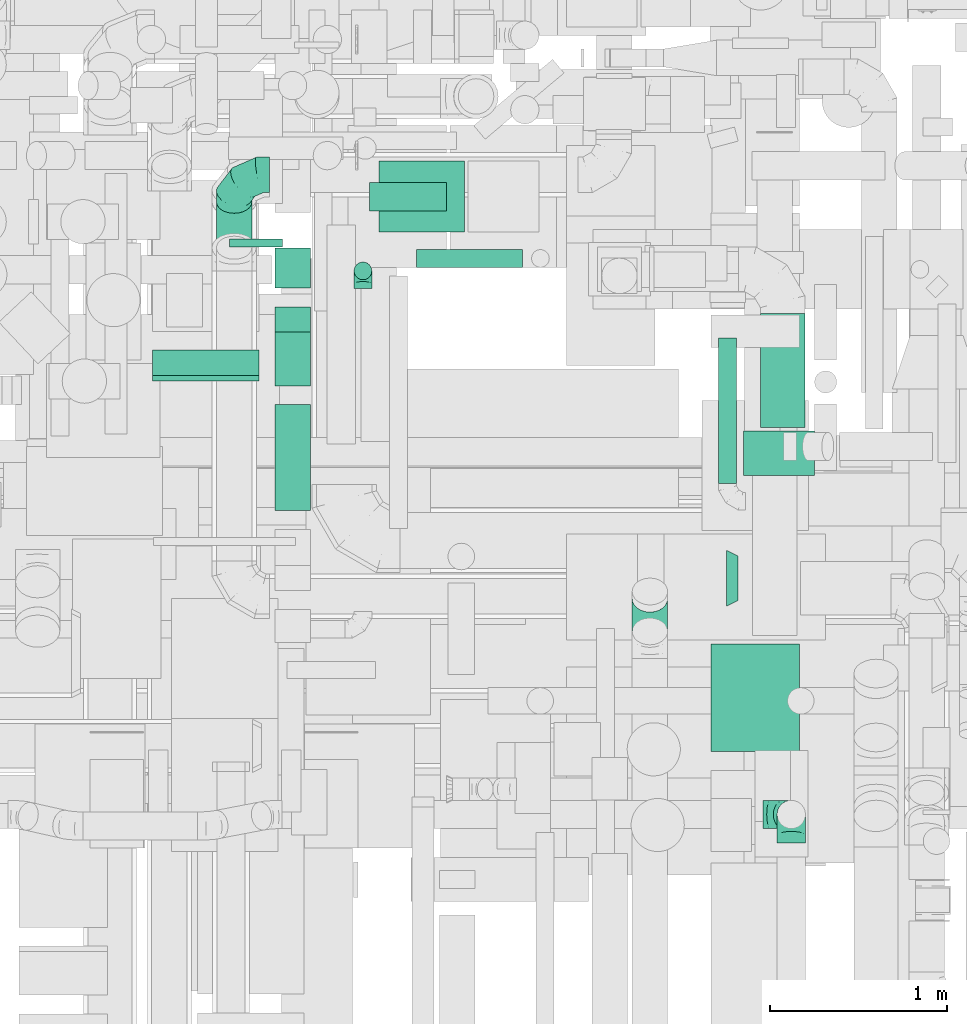
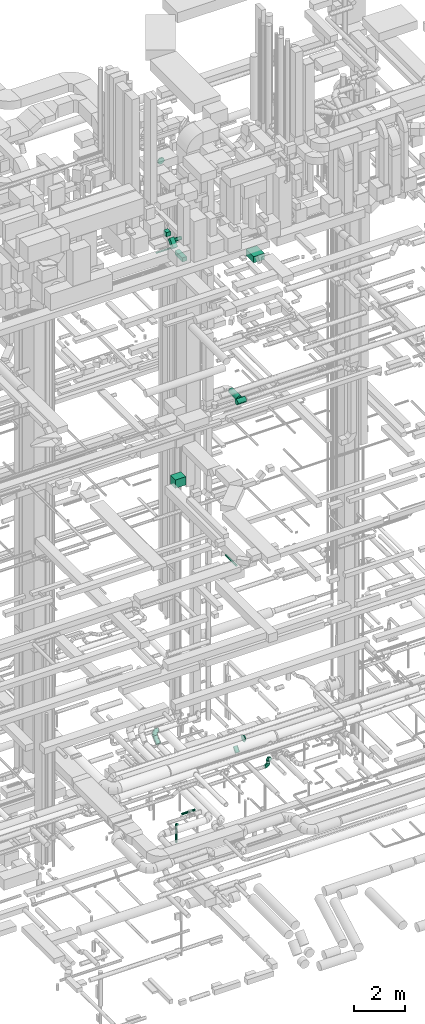
# One storey, part 186 of 337: 15 flow segments, 5 flow fittings.
"""IFC2X3 building model written with IfcOpenShell, lengths in millimetres."""

import ifcopenshell
import ifcopenshell.guid

model = None  # the IFC model being written
_history = None  # IfcOwnerHistory: only IFC2X3 demands one
_inside = {}  # id of a spatial element -> (the spatial element, [elements in it])
_under = {}  # id of a project, library or spatial element -> (it, [spatial elements below it])
_declared = {}  # id of a project -> (the project, [libraries it declares])
_typed = {}  # id of a type object -> (the type object, [elements of that type])
_made_of = {}  # id of a material, layer set ... -> (it, [elements and type objects made of it])


def new_model(schema):
    """Start an empty IFC model of exactly this schema.

    Asked for "IFC4X3", IfcOpenShell would pick the latest addendum, in which some entities
    have other attributes; the version numbers below select the first issue.
    IFC2X3 requires an IfcOwnerHistory on every rooted entity: one is made here for all.
    """
    global model, _history
    if schema == "IFC4X3":
        model = ifcopenshell.file(schema_version=(4, 3, 0, 0))
    else:
        model = ifcopenshell.file(schema=schema)
    _inside.clear()
    _under.clear()
    _declared.clear()
    _typed.clear()
    _made_of.clear()
    _history = None
    if model.schema == "IFC2X3":
        org = make("IfcOrganization", Name="unknown")
        user = make(
            "IfcPersonAndOrganization",
            ThePerson=make("IfcPerson", FamilyName="unknown"),
            TheOrganization=org,
        )
        app = make(
            "IfcApplication",
            ApplicationDeveloper=org,
            Version="unknown",
            ApplicationFullName="unknown",
            ApplicationIdentifier="unknown",
        )
        _history = make(
            "IfcOwnerHistory",
            OwningUser=user,
            OwningApplication=app,
            ChangeAction="ADDED",
            CreationDate=0,
        )
    return model


def make(cls, **values):
    """One entity of the class cls with the attributes given. An attribute that is None is left unset."""
    return model.create_entity(
        cls, **{name: value for name, value in values.items() if value is not None}
    )


def entity(cls, *values):
    """Any entity or typed value of the class cls, its attributes in the order of the schema. None: left unset."""
    e = model.create_entity(cls)
    for i, value in enumerate(values):
        if value is not None:
            e[i] = value
    return e


def rooted(cls, **values):
    """An entity with a GlobalId (a new one), such as an element, a storey or a relation."""
    return make(cls, GlobalId=ifcopenshell.guid.new(), OwnerHistory=_history, **values)


def si_unit(unit_type, name, prefix=None):
    """IfcSIUnit, for example si_unit("LENGTHUNIT", "METRE", prefix="MILLI")."""
    return make("IfcSIUnit", UnitType=unit_type, Prefix=prefix, Name=name)


def converted_unit(unit_type, name, factor, base, dimensions=None, offset=None):
    """IfcConversionBasedUnit, such as the inch: factor (a typed value) times the base unit."""
    return make(
        "IfcConversionBasedUnit"
        if offset is None
        else "IfcConversionBasedUnitWithOffset",
        ConversionOffset=offset,
        Dimensions=None
        if dimensions is None
        else entity("IfcDimensionalExponents", *dimensions),
        UnitType=unit_type,
        Name=name,
        ConversionFactor=make(
            "IfcMeasureWithUnit", ValueComponent=factor, UnitComponent=base
        ),
    )


def derived_unit(unit_type, elements):
    """IfcDerivedUnit: a product of units, each with its exponent."""
    return make(
        "IfcDerivedUnit",
        Elements=[
            make("IfcDerivedUnitElement", Unit=unit, Exponent=power)
            for unit, power in elements
        ],
        UnitType=unit_type,
    )


def assignment(units):
    """IfcUnitAssignment: the units of a project."""
    return None if units is None else make("IfcUnitAssignment", Units=units)


def point(xyz):
    """IfcCartesianPoint."""
    return None if xyz is None else make("IfcCartesianPoint", Coordinates=xyz)


def direction(xyz):
    """IfcDirection."""
    return None if xyz is None else make("IfcDirection", DirectionRatios=xyz)


def frame(location, z_axis=None, x_axis=None):
    """IfcAxis2Placement3D, a coordinate frame: its origin and axes. An axis left out is left unset."""
    return make(
        "IfcAxis2Placement3D",
        Location=point(location),
        Axis=direction(z_axis),
        RefDirection=direction(x_axis),
    )


def frame_2d(location, x_axis=None):
    """IfcAxis2Placement2D, a coordinate frame in the plane: its origin and x axis."""
    return make(
        "IfcAxis2Placement2D", Location=point(location), RefDirection=direction(x_axis)
    )


def origin():
    """The frame at (0, 0, 0) with its axes left unset."""
    return frame((0.0, 0.0, 0.0))


def origin_2d_with_axis():
    """The frame at (0, 0) in the plane with the x axis (1, 0) written out."""
    return frame_2d((0.0, 0.0), x_axis=(1.0, 0.0))


def place(relative_to, where):
    """IfcLocalPlacement: puts the frame where relative to a parent placement (None: the world)."""
    return make(
        "IfcLocalPlacement", PlacementRelTo=relative_to, RelativePlacement=where
    )


def context(
    kind, dimensions, precision=None, world=None, true_north=None, identifier=None
):
    """IfcGeometricRepresentationContext, for example the 3D "Model" context."""
    return make(
        "IfcGeometricRepresentationContext",
        ContextIdentifier=identifier,
        ContextType=kind,
        CoordinateSpaceDimension=dimensions,
        Precision=precision,
        WorldCoordinateSystem=world,
        TrueNorth=true_north,
    )


def subcontext(parent, identifier, kind, view, scale=None):
    """IfcGeometricRepresentationSubContext, for example "Body" below "Model"."""
    return make(
        "IfcGeometricRepresentationSubContext",
        ContextIdentifier=identifier,
        ContextType=kind,
        ParentContext=parent,
        TargetScale=scale,
        TargetView=view,
    )


def project(units=None, contexts=None):
    """IfcProject with its units and contexts."""
    return rooted(
        "IfcProject",
        Name="project",
        RepresentationContexts=contexts,
        UnitsInContext=assignment(units),
    )


def spatial(cls, under=None, at=None, **own):
    """A site, building, storey or space (cls), placed at a placement, below another one or the project."""
    s = rooted(cls, ObjectPlacement=at, **own)
    if under is not None:
        _under.setdefault(under.id(), (under, []))[1].append(s)
    return s


def profile(cls, at=None, kind="AREA", **sizes):
    """A parametric profile (cls). Its sizes go by their IFC names, for example OverallWidth=200.0."""
    return make(cls, ProfileType=kind, Position=at, **sizes)


def rectangle(**sizes):
    """IfcRectangleProfileDef."""
    return profile("IfcRectangleProfileDef", **sizes)


def circle(**sizes):
    """IfcCircleProfileDef."""
    return profile("IfcCircleProfileDef", **sizes)


def extrude(swept, where, along, depth):
    """IfcExtrudedAreaSolid: the profile swept, set in the frame where, extruded along a direction by depth."""
    return make(
        "IfcExtrudedAreaSolid",
        SweptArea=swept,
        Position=where,
        ExtrudedDirection=direction(along),
        Depth=depth,
    )


def faces_of(points, faces, orient=None, outer=None):
    """IfcFace entities. A face is a list of loops; a loop is a list of indices into points, from 0.

    orient and outer hold one flag for each loop. By default every Orientation is true, the
    first loop of a face is its IfcFaceOuterBound and the others are IfcFaceBound.
    """
    made = []
    for i, loops in enumerate(faces):
        bounds = []
        for j, loop in enumerate(loops):
            is_outer = j == 0 if outer is None else outer[i][j]
            bounds.append(
                make(
                    "IfcFaceOuterBound" if is_outer else "IfcFaceBound",
                    Bound=make("IfcPolyLoop", Polygon=[points[k] for k in loop]),
                    Orientation=True if orient is None else orient[i][j],
                )
            )
        made.append(make("IfcFace", Bounds=bounds))
    return made


def faceted_brep(points, faces, orient=None, outer=None, voids=None):
    """IfcFacetedBrep: a solid bounded by flat faces; with voids (closed shells), ...WithVoids."""
    shared = [point(p) for p in points]
    hull = make("IfcClosedShell", CfsFaces=faces_of(shared, faces, orient, outer))
    if voids is None:
        return make("IfcFacetedBrep", Outer=hull)
    return make(
        "IfcFacetedBrepWithVoids",
        Outer=hull,
        Voids=[
            make(cls, CfsFaces=faces_of(shared, fs, o, b)) for cls, fs, o, b in voids
        ],
    )


def shape(context_of_items, identifier, shape_type, items):
    """IfcShapeRepresentation: the items that make up one representation, for example the "Body"."""
    return make(
        "IfcShapeRepresentation",
        ContextOfItems=context_of_items,
        RepresentationIdentifier=identifier,
        RepresentationType=shape_type,
        Items=items,
    )


def source(mapping_origin, context_of_items, identifier, shape_type, items):
    """IfcRepresentationMap: a shape defined once, which mapped items show again and again."""
    return make(
        "IfcRepresentationMap",
        MappingOrigin=mapping_origin,
        MappedRepresentation=shape(context_of_items, identifier, shape_type, items),
    )


def transform(
    local_origin,
    x_axis=None,
    y_axis=None,
    z_axis=None,
    scale=None,
    scale2=None,
    scale3=None,
    uniform=True,
):
    """IfcCartesianTransformationOperator3D, or its non-uniform kind. x_axis, y_axis, z_axis: its Axis1, 2, 3."""
    if uniform:
        return make(
            "IfcCartesianTransformationOperator3D",
            Axis1=direction(x_axis),
            Axis2=direction(y_axis),
            LocalOrigin=point(local_origin),
            Scale=scale,
            Axis3=direction(z_axis),
        )
    return make(
        "IfcCartesianTransformationOperator3DnonUniform",
        Axis1=direction(x_axis),
        Axis2=direction(y_axis),
        LocalOrigin=point(local_origin),
        Scale=scale,
        Axis3=direction(z_axis),
        Scale2=scale2,
        Scale3=scale3,
    )


def mapped(mapping_source, mapping_target):
    """IfcMappedItem: shows the shape of a source again, moved by a transform."""
    return make(
        "IfcMappedItem", MappingSource=mapping_source, MappingTarget=mapping_target
    )


def material(Name=None, Category=None):
    """IfcMaterial."""
    return make("IfcMaterial", Name=Name, Category=Category)


def made_of(thing, what):
    """Note that an element or type object is made of a material, layer set ...; save() writes the relation."""
    if what is not None:
        _made_of.setdefault(what.id(), (what, []))[1].append(thing)
    return thing


def type_object(cls, material=None, **own):
    """A type object (cls), such as IfcWallType, which elements share."""
    return made_of(rooted(cls, **own), material)


def type_shapes(of_type, sources):
    """Give a type object the sources (RepresentationMaps) that its elements show as mapped items."""
    of_type.RepresentationMaps = sources


def element(
    cls,
    number,
    at=None,
    inside=None,
    cuts=None,
    type_object=None,
    material=None,
    context=None,
    identifier="Body",
    shape_type=None,
    held_by="IfcProductDefinitionShape",
    body=None,
    shapes=None,
    **own,
):
    """One element of the class cls, such as IfcWall. Its Tag is "e" and its number.

    at: its placement. inside: the storey or other place that contains it. cuts: it is an
    opening in that element (IfcRelVoidsElement). A single representation is given by context,
    identifier, shape_type and body (its items); several are given by shapes. held_by: the class
    of the entity that holds the representations. save() writes the other relations.
    """
    e = rooted(cls, Tag="e%d" % number, ObjectPlacement=at, **own)
    if body is not None:
        shapes = [shape(context, identifier, shape_type, body)]
    if shapes is not None:
        e.Representation = make(held_by, Representations=shapes)
    if inside is not None:
        _inside.setdefault(inside.id(), (inside, []))[1].append(e)
    if cuts is not None:
        rooted(
            "IfcRelVoidsElement", RelatingBuildingElement=cuts, RelatedOpeningElement=e
        )
    if type_object is not None:
        _typed.setdefault(type_object.id(), (type_object, []))[1].append(e)
    return made_of(e, material)


def aggregate(whole, parts):
    """IfcRelAggregates: a whole, such as a stair, and the parts it consists of."""
    return rooted("IfcRelAggregates", RelatingObject=whole, RelatedObjects=parts)


def save(model, path):
    """Write the relations noted so far, then the file.

    IfcRelAggregates (storeys below a building ...), IfcRelContainedInSpatialStructure (elements
    in a storey), IfcRelDefinesByType, IfcRelAssociatesMaterial and IfcRelDeclares: one each for
    every whole, place, type object, material and project.
    """
    for whole, parts in _under.values():
        aggregate(whole, parts)
    for where, things in _inside.values():
        rooted(
            "IfcRelContainedInSpatialStructure",
            RelatedElements=things,
            RelatingStructure=where,
        )
    for kind, things in _typed.values():
        rooted("IfcRelDefinesByType", RelatedObjects=things, RelatingType=kind)
    for what, things in _made_of.values():
        rooted("IfcRelAssociatesMaterial", RelatedObjects=things, RelatingMaterial=what)
    for by, libraries in _declared.values():
        rooted("IfcRelDeclares", RelatingContext=by, RelatedDefinitions=libraries)
    model.write(path)


model = new_model("IFC2X3")

# Units and contexts
model_context = context("Model", 3, precision=0.01, world=origin(), true_north=direction((6.12303176911189e-17, 1.0)))
body_context = subcontext(model_context, "Body", "Model", "MODEL_VIEW")
ifc_project = project(units=[si_unit("LENGTHUNIT", "METRE", prefix="MILLI"), si_unit("AREAUNIT", "SQUARE_METRE"), si_unit("VOLUMEUNIT", "CUBIC_METRE"), converted_unit("PLANEANGLEUNIT", "DEGREE", entity("IfcRatioMeasure", 0.0174532925199433), si_unit("PLANEANGLEUNIT", "RADIAN"), dimensions=[0, 0, 0, 0, 0, 0, 0]), si_unit("MASSUNIT", "GRAM", prefix="KILO"), derived_unit("MASSDENSITYUNIT", [(si_unit("MASSUNIT", "GRAM", prefix="KILO"), 1), (si_unit("LENGTHUNIT", "METRE"), -3)]), derived_unit("MOMENTOFINERTIAUNIT", [(si_unit("LENGTHUNIT", "METRE"), 4)]), si_unit("TIMEUNIT", "SECOND"), si_unit("FREQUENCYUNIT", "HERTZ"), si_unit("THERMODYNAMICTEMPERATUREUNIT", "DEGREE_CELSIUS"), derived_unit("THERMALTRANSMITTANCEUNIT", [(si_unit("MASSUNIT", "GRAM", prefix="KILO"), 1), (si_unit("THERMODYNAMICTEMPERATUREUNIT", "KELVIN"), -1), (si_unit("TIMEUNIT", "SECOND"), -3)]), derived_unit("VOLUMETRICFLOWRATEUNIT", [(si_unit("LENGTHUNIT", "METRE"), 3), (si_unit("TIMEUNIT", "SECOND"), -1)]), derived_unit("MASSFLOWRATEUNIT", [(si_unit("MASSUNIT", "GRAM", prefix="KILO"), 1), (si_unit("TIMEUNIT", "SECOND"), -1)]), derived_unit("ROTATIONALFREQUENCYUNIT", [(si_unit("TIMEUNIT", "SECOND"), -1)]), si_unit("ELECTRICCURRENTUNIT", "AMPERE"), si_unit("ELECTRICVOLTAGEUNIT", "VOLT"), si_unit("POWERUNIT", "WATT"), si_unit("FORCEUNIT", "NEWTON", prefix="KILO"), si_unit("ILLUMINANCEUNIT", "LUX"), si_unit("LUMINOUSFLUXUNIT", "LUMEN"), si_unit("LUMINOUSINTENSITYUNIT", "CANDELA"), derived_unit("USERDEFINED", [(si_unit("MASSUNIT", "GRAM", prefix="KILO"), -1), (si_unit("LENGTHUNIT", "METRE"), -2), (si_unit("TIMEUNIT", "SECOND"), 3), (si_unit("LUMINOUSFLUXUNIT", "LUMEN"), 1)]), derived_unit("LINEARVELOCITYUNIT", [(si_unit("LENGTHUNIT", "METRE"), 1), (si_unit("TIMEUNIT", "SECOND"), -1)]), si_unit("PRESSUREUNIT", "PASCAL"), derived_unit("USERDEFINED", [(si_unit("LENGTHUNIT", "METRE"), -2), (si_unit("MASSUNIT", "GRAM", prefix="KILO"), 1), (si_unit("TIMEUNIT", "SECOND"), -2)]), derived_unit("LINEARFORCEUNIT", [(si_unit("MASSUNIT", "GRAM", prefix="KILO"), 1), (si_unit("LENGTHUNIT", "METRE"), 1), (si_unit("TIMEUNIT", "SECOND"), -2), (si_unit("LENGTHUNIT", "METRE"), -1)]), derived_unit("PLANARFORCEUNIT", [(si_unit("MASSUNIT", "GRAM", prefix="KILO"), 1), (si_unit("LENGTHUNIT", "METRE"), 1), (si_unit("TIMEUNIT", "SECOND"), -2), (si_unit("LENGTHUNIT", "METRE"), -2)])], contexts=[model_context])

# Site, building, storey
site_placement = place(None, origin())
site = spatial("IfcSite", under=ifc_project, at=site_placement, CompositionType="ELEMENT")
building_placement = place(site_placement, origin())
building = spatial("IfcBuilding", under=site, at=building_placement, CompositionType="ELEMENT")
storey_placement = place(building_placement, origin())
storey = spatial("IfcBuildingStorey", under=building, at=storey_placement, CompositionType="ELEMENT", Elevation=0.0)

# Flow segments
duct_segment_type_1 = type_object("IfcDuctSegmentType", PredefinedType="NOTDEFINED")
flow_segment_1_placement = place(storey_placement, frame((51245.32, 11485.34, 15050.0)))
element("IfcFlowSegment", 1, at=flow_segment_1_placement, inside=storey, type_object=duct_segment_type_1, context=body_context, shape_type="SweptSolid", body=[
    extrude(rectangle(XDim=479.889877624802, YDim=400.0, at=origin_2d_with_axis()), frame((239.94, 200.0, 0.0), z_axis=(0.0, 0.0, 1.0), x_axis=(-1.0, 0.0, 0.0)), (0.0, 0.0, 1.0), 400.0),
])
flow_segment_2_placement = place(storey_placement, frame((49966.44, 10643.16, 27222.51)))
element("IfcFlowSegment", 2, at=flow_segment_2_placement, inside=storey, type_object=duct_segment_type_1, context=body_context, shape_type="SweptSolid", body=[
    extrude(rectangle(XDim=47.451660040764, YDim=199.999999999996, at=origin_2d_with_axis()), frame((0.0, 87.49, 87.49), z_axis=(1.0, 0.0, 0.0), x_axis=(0.0, -0.707106781186502, -0.707106781186593)), (0.0, 0.0, 1.0), 600.000000000002),
])
flow_segment_3_placement = place(storey_placement, frame((50656.62, 9913.65, 27100.0)))
element("IfcFlowSegment", 3, at=flow_segment_3_placement, inside=storey, type_object=duct_segment_type_1, context=body_context, shape_type="SweptSolid", body=[
    extrude(rectangle(XDim=597.695447254163, YDim=199.999999999998, at=origin_2d_with_axis()), frame((100.0, 298.85, 0.0), z_axis=(0.0, 0.0, 1.0), x_axis=(0.0, 1.0, 0.0)), (0.0, 0.0, 1.0), 199.999999999998),
])
flow_segment_4_placement = place(storey_placement, frame((50656.62, 11168.45, 27550.0)))
element("IfcFlowSegment", 4, at=flow_segment_4_placement, inside=storey, type_object=duct_segment_type_1, context=body_context, shape_type="SweptSolid", body=[
    extrude(rectangle(XDim=227.123541719797, YDim=199.999999999998, at=origin_2d_with_axis()), frame((100.0, 113.56, 0.0), z_axis=(0.0, 0.0, 1.0), x_axis=(0.0, -1.0, 0.0)), (0.0, 0.0, 1.0), 199.999999999998),
])
flow_segment_5_placement = place(storey_placement, frame((50656.62, 10617.41, 27202.51)))
element("IfcFlowSegment", 5, at=flow_segment_5_placement, inside=storey, type_object=duct_segment_type_1, context=body_context, shape_type="SweptSolid", body=[
    extrude(rectangle(XDim=200.000000000001, YDim=200.000000000007, at=frame_2d((0.0, 0.0), x_axis=(0.0, 1.0))), frame((100.0, 70.71, 70.71), z_axis=(0.0, 0.707106781186526, 0.707106781186569), x_axis=(-1.0, 0.0, 0.0)), (0.0, 0.0, 1.0), 429.28932188139),
])
flow_segment_6_placement = place(storey_placement, frame((53115.82, 8554.1, 27020.0)))
element("IfcFlowSegment", 6, at=flow_segment_6_placement, inside=storey, type_object=duct_segment_type_1, context=body_context, shape_type="SweptSolid", body=[
    extrude(rectangle(XDim=608.455931288087, YDim=499.999999999999, at=origin_2d_with_axis()), frame((250.0, 304.23, 0.0), z_axis=(0.0, 0.0, 1.0), x_axis=(0.0, -1.0, 0.0)), (0.0, 0.0, 1.0), 300.000000000001),
])
duct_segment_type_2 = type_object("IfcDuctSegmentType", PredefinedType="NOTDEFINED")
flow_segment_7_placement = place(storey_placement, frame((51101.93, 11213.41, -1800.0)))
element("IfcFlowSegment", 7, at=flow_segment_7_placement, inside=storey, type_object=duct_segment_type_2, context=body_context, shape_type="SweptSolid", body=[
    extrude(circle(Radius=50.0, at=origin_2d_with_axis()), frame((51.6, 51.6, 0.0), z_axis=(0.0, 0.0, 1.0), x_axis=(-1.0, 0.0, 0.0)), (0.0, 0.0, 1.0), 799.999999999994),
])
flow_segment_8_placement = place(storey_placement, frame((53158.29, 10066.79, 11468.4)))
element("IfcFlowSegment", 8, at=flow_segment_8_placement, inside=storey, type_object=duct_segment_type_2, context=body_context, shape_type="SweptSolid", body=[
    extrude(circle(Radius=50.0, at=origin_2d_with_axis()), frame((51.6, 0.0, 51.6), z_axis=(0.0, 1.0, 0.0), x_axis=(1.0, 0.0, 0.0)), (0.0, 0.0, 1.0), 820.000000000015),
])
flow_segment_9_placement = place(storey_placement, frame((53393.29, 10382.4, 19123.4)))
element("IfcFlowSegment", 9, at=flow_segment_9_placement, inside=storey, type_object=duct_segment_type_2, context=body_context, shape_type="SweptSolid", body=[
    extrude(circle(Radius=125.0, at=origin_2d_with_axis()), frame((126.6, 0.0, 126.6), z_axis=(0.0, 1.0, 0.0), x_axis=(-1.0, 0.0, 0.0)), (0.0, 0.0, 1.0), 642.208810038309),
])
flow_segment_10_placement = place(storey_placement, frame((53299.89, 10110.8, 19123.4)))
element("IfcFlowSegment", 10, at=flow_segment_10_placement, inside=storey, type_object=duct_segment_type_2, context=body_context, shape_type="SweptSolid", body=[
    extrude(circle(Radius=125.0, at=origin_2d_with_axis()), frame((0.0, 126.6, 126.6), z_axis=(1.0, 0.0, 0.0), x_axis=(0.0, -1.0, 0.0)), (0.0, 0.0, 1.0), 399.999999999996),
])
flow_segment_11_placement = place(storey_placement, frame((51190.74, 11602.23, 26778.4)))
element("IfcFlowSegment", 11, at=flow_segment_11_placement, inside=storey, type_object=duct_segment_type_2, context=body_context, shape_type="SweptSolid", body=[
    extrude(circle(Radius=80.0, at=origin_2d_with_axis()), frame((0.0, 81.6, 81.6), z_axis=(1.0, 0.0, 0.0), x_axis=(0.0, 1.0, 0.0)), (0.0, 0.0, 1.0), 434.464444213462),
])
flow_segment_12_placement = place(storey_placement, frame((50398.26, 11400.25, 30948.4)))
element("IfcFlowSegment", 12, at=flow_segment_12_placement, inside=storey, type_object=duct_segment_type_2, context=body_context, shape_type="SweptSolid", body=[
    extrude(circle(Radius=150.0, at=origin_2d_with_axis()), frame((151.6, 0.0, 151.6), z_axis=(0.0, 1.0, 0.0), x_axis=(1.0, 0.0, 0.0)), (0.0, 0.0, 1.0), 46.000000000009),
])
flow_segment_13_placement = place(storey_placement, frame((51454.28, 11283.75, -651.6)))
element("IfcFlowSegment", 13, at=flow_segment_13_placement, inside=storey, type_object=duct_segment_type_2, context=body_context, shape_type="SweptSolid", body=[
    extrude(circle(Radius=50.0, at=origin_2d_with_axis()), frame((0.0, 51.6, 51.6), z_axis=(1.0, 0.0, 0.0), x_axis=(0.0, 1.0, 0.0)), (0.0, 0.0, 1.0), 600.000000000011),
])
flow_segment_14_placement = place(storey_placement, frame((52670.27, 9154.84, 3103.17)))
element("IfcFlowSegment", 14, at=flow_segment_14_placement, inside=storey, type_object=duct_segment_type_2, context=body_context, shape_type="SweptSolid", body=[
    extrude(circle(Radius=100.0, at=origin_2d_with_axis()), frame((101.6, 77.52, 66.67), z_axis=(0.0, 0.650791373455976, 0.75925660236529), x_axis=(1.0, 0.0, 0.0)), (0.0, 0.0, 1.0), 283.68568294348),
])
flow_segment_15_placement = place(storey_placement, frame((50325.56, 11329.47, 3020.56)))
element("IfcFlowSegment", 15, at=flow_segment_15_placement, inside=storey, type_object=duct_segment_type_2, context=body_context, shape_type="SweptSolid", body=[
    extrude(circle(Radius=100.0, at=origin_2d_with_axis()), frame((101.6, 66.65, 77.54), z_axis=(0.0, 0.759487168515649, 0.650522283138773), x_axis=(-1.0, 0.0, 0.0)), (0.0, 0.0, 1.0), 340.946010343046),
])

# Flow fittings
ifc_material = material()
duct_fitting_type_1 = type_object("IfcDuctFittingType", PredefinedType="NOTDEFINED", material=ifc_material)
shared_shape_1 = source(origin(), body_context, "Body", "Brep", [
    faceted_brep([(-160.0, 0.0, -80.0), (-160.0, -20.71, -77.27), (-160.0, -40.0, -69.28), (-160.0, -56.57, -56.57), (-160.0, -69.28, -40.0), (-160.0, -77.27, -20.71), (-160.0, -80.0, 0.0), (-160.0, -77.27, 20.71), (-160.0, -69.28, 40.0), (-160.0, -56.57, 56.57), (-160.0, -40.0, 69.28), (-160.0, -20.71, 77.27), (-160.0, 0.0, 80.0), (-160.0, 20.71, 77.27), (-160.0, 40.0, 69.28), (-160.0, 56.57, 56.57), (-160.0, 69.28, 40.0), (-160.0, 77.27, 20.71), (-160.0, 80.0, 0.0), (-160.0, 77.27, -20.71), (-160.0, 69.28, -40.0), (-160.0, 56.57, -56.57), (-160.0, 40.0, -69.28), (-160.0, 20.71, -77.27), (-122.68, 20.71, 77.27), (-127.85, 40.0, 69.28), (-117.13, 0.0, 80.0), (-132.29, 56.57, 56.57), (-137.83, 77.27, 20.71), (-138.56, 80.0, 0.0), (-135.69, 69.28, 40.0), (-135.69, 69.28, -40.0), (-132.29, 56.57, -56.57), (-137.83, 77.27, -20.71), (-122.68, 20.71, -77.27), (-117.13, 0.0, -80.0), (-127.85, 40.0, -69.28), (-111.58, -20.71, -77.27), (-106.41, -40.0, -69.28), (-101.97, -56.57, -56.57), (-98.56, -69.28, -40.0), (-96.42, -77.27, -20.71), (-95.69, -80.0, 0.0), (-96.42, -77.27, 20.71), (-98.56, -69.28, 40.0), (-101.97, -56.57, 56.57), (-106.41, -40.0, 69.28), (-111.58, -20.71, 77.27), (-58.03, 58.03, 77.27), (-72.15, 72.15, 69.28), (-42.87, 42.87, 80.0), (-84.28, 84.28, 56.57), (-93.59, 93.59, 40.0), (-99.44, 99.44, 20.71), (-101.44, 101.44, 0.0), (-99.44, 99.44, -20.71), (-93.59, 93.59, -40.0), (-84.28, 84.28, -56.57), (-58.03, 58.03, -77.27), (-42.87, 42.87, -80.0), (-72.15, 72.15, -69.28), (-27.71, 27.71, -77.27), (-13.59, 13.59, -69.28), (-1.46, 1.46, -56.57), (7.85, -7.85, -40.0), (13.7, -13.7, -20.71), (15.69, -15.69, 0.0), (13.7, -13.7, 20.71), (7.85, -7.85, 40.0), (-1.46, 1.46, 56.57), (-13.59, 13.59, 69.28), (-27.71, 27.71, 77.27), (-20.71, 122.68, 77.27), (-40.0, 127.85, 69.28), (0.0, 117.13, 80.0), (-56.57, 132.29, 56.57), (-69.28, 135.69, 40.0), (-77.27, 137.83, 20.71), (-80.0, 138.56, 0.0), (-77.27, 137.83, -20.71), (-69.28, 135.69, -40.0), (-56.57, 132.29, -56.57), (-20.71, 122.68, -77.27), (0.0, 117.13, -80.0), (-40.0, 127.85, -69.28), (20.71, 111.58, -77.27), (40.0, 106.41, -69.28), (56.57, 101.97, -56.57), (69.28, 98.56, -40.0), (77.27, 96.42, -20.71), (80.0, 95.69, 0.0), (77.27, 96.42, 20.71), (69.28, 98.56, 40.0), (56.57, 101.97, 56.57), (40.0, 106.41, 69.28), (20.71, 111.58, 77.27), (-20.71, 160.0, -77.27), (-40.0, 160.0, -69.28), (-56.57, 160.0, -56.57), (-69.28, 160.0, -40.0), (-77.27, 160.0, -20.71), (-80.0, 160.0, 0.0), (-77.27, 160.0, 20.71), (-69.28, 160.0, 40.0), (-56.57, 160.0, 56.57), (-40.0, 160.0, 69.28), (-20.71, 160.0, 77.27), (0.0, 160.0, 80.0), (20.71, 160.0, 77.27), (40.0, 160.0, 69.28), (56.57, 160.0, 56.57), (69.28, 160.0, 40.0), (77.27, 160.0, 20.71), (80.0, 160.0, 0.0), (77.27, 160.0, -20.71), (69.28, 160.0, -40.0), (56.57, 160.0, -56.57), (40.0, 160.0, -69.28), (20.71, 160.0, -77.27), (0.0, 160.0, -80.0)], [[[0, 1, 2, 3, 4, 5, 6, 7, 8, 9, 10, 11, 12, 13, 14, 15, 16, 17, 18, 19, 20, 21, 22, 23]], [[24, 25, 14, 13]], [[26, 24, 13, 12]], [[14, 25, 27, 15]], [[28, 29, 18, 17]], [[30, 28, 17, 16]], [[15, 27, 30, 16]], [[20, 31, 32, 21]], [[33, 31, 20, 19]], [[18, 29, 33, 19]], [[34, 35, 0, 23]], [[36, 34, 23, 22]], [[32, 36, 22, 21]], [[1, 0, 35, 37]], [[2, 1, 37, 38]], [[3, 2, 38, 39]], [[5, 4, 40, 41]], [[6, 5, 41, 42]], [[39, 40, 4, 3]], [[6, 42, 43, 7]], [[7, 43, 44, 8]], [[8, 44, 45, 9]], [[9, 45, 46, 10]], [[10, 46, 47, 11]], [[26, 12, 11, 47]], [[48, 49, 25, 24]], [[50, 48, 24, 26]], [[27, 25, 49, 51]], [[52, 53, 28, 30]], [[51, 52, 30, 27]], [[29, 28, 53, 54]], [[55, 56, 31, 33]], [[54, 55, 33, 29]], [[32, 31, 56, 57]], [[58, 59, 35, 34]], [[60, 58, 34, 36]], [[57, 60, 36, 32]], [[37, 35, 59, 61]], [[38, 37, 61, 62]], [[39, 38, 62, 63]], [[41, 40, 64, 65]], [[42, 41, 65, 66]], [[63, 64, 40, 39]], [[43, 42, 66, 67]], [[44, 43, 67, 68]], [[68, 69, 45, 44]], [[46, 45, 69, 70]], [[47, 46, 70, 71]], [[26, 47, 71, 50]], [[72, 73, 49, 48]], [[74, 72, 48, 50]], [[51, 49, 73, 75]], [[76, 77, 53, 52]], [[75, 76, 52, 51]], [[54, 53, 77, 78]], [[79, 80, 56, 55]], [[78, 79, 55, 54]], [[57, 56, 80, 81]], [[82, 83, 59, 58]], [[84, 82, 58, 60]], [[81, 84, 60, 57]], [[61, 59, 83, 85]], [[62, 61, 85, 86]], [[63, 62, 86, 87]], [[65, 64, 88, 89]], [[66, 65, 89, 90]], [[87, 88, 64, 63]], [[67, 66, 90, 91]], [[68, 67, 91, 92]], [[92, 93, 69, 68]], [[70, 69, 93, 94]], [[71, 70, 94, 95]], [[50, 71, 95, 74]], [[96, 97, 98, 99, 100, 101, 102, 103, 104, 105, 106, 107, 108, 109, 110, 111, 112, 113, 114, 115, 116, 117, 118, 119]], [[72, 74, 107, 106]], [[73, 72, 106, 105]], [[75, 73, 105, 104]], [[77, 76, 103, 102]], [[78, 77, 102, 101]], [[75, 104, 103, 76]], [[78, 101, 100, 79]], [[79, 100, 99, 80]], [[80, 99, 98, 81]], [[84, 97, 96, 82]], [[82, 96, 119, 83]], [[84, 81, 98, 97]], [[118, 117, 86, 85]], [[119, 118, 85, 83]], [[116, 87, 86, 117]], [[88, 115, 114, 89]], [[89, 114, 113, 90]], [[115, 88, 87, 116]], [[112, 111, 92, 91]], [[113, 112, 91, 90]], [[111, 110, 93, 92]], [[95, 94, 109, 108]], [[74, 95, 108, 107]], [[110, 109, 94, 93]]]),
])
type_shapes(duct_fitting_type_1, [shared_shape_1])
for number, where, z_axis, x_axis in (
    (16, (53568.9, 8200.02, 3300.0), (-1.0, 0.0, 0.0), (0.0, 1.0, 0.0)),
    (17, (53568.9, 8200.02, 2900.0), (0.0, 1.0, 0.0), (0.0, 0.0, -1.0)),
):
    element("IfcFlowFitting", number, at=place(storey_placement, frame(where, z_axis=z_axis, x_axis=x_axis)), inside=storey, type_object=duct_fitting_type_1, material=ifc_material, context=body_context, shape_type="MappedRepresentation", body=[
        mapped(shared_shape_1, transform((0.0, 0.0, 0.0), scale=1.0)),
    ])
duct_fitting_type_2 = type_object("IfcDuctFittingType", PredefinedType="NOTDEFINED", material=ifc_material)
shared_shape_2 = source(origin(), body_context, "Body", "Brep", [
    faceted_brep([(-100.0, 0.0, -50.0), (-100.0, -12.94, -48.3), (-100.0, -25.0, -43.3), (-100.0, -35.36, -35.36), (-100.0, -43.3, -25.0), (-100.0, -48.3, -12.94), (-100.0, -50.0, 0.0), (-100.0, -48.3, 12.94), (-100.0, -43.3, 25.0), (-100.0, -35.36, 35.36), (-100.0, -25.0, 43.3), (-100.0, -12.94, 48.3), (-100.0, 0.0, 50.0), (-100.0, 12.94, 48.3), (-100.0, 25.0, 43.3), (-100.0, 35.36, 35.36), (-100.0, 43.3, 25.0), (-100.0, 48.3, 12.94), (-100.0, 50.0, 0.0), (-100.0, 48.3, -12.94), (-100.0, 43.3, -25.0), (-100.0, 35.36, -35.36), (-100.0, 25.0, -43.3), (-100.0, 12.94, -48.3), (-76.67, 12.94, 48.3), (-79.9, 25.0, 43.3), (-73.21, 0.0, 50.0), (-82.68, 35.36, 35.36), (-86.15, 48.3, 12.94), (-86.6, 50.0, 0.0), (-84.81, 43.3, 25.0), (-84.81, 43.3, -25.0), (-82.68, 35.36, -35.36), (-86.15, 48.3, -12.94), (-76.67, 12.94, -48.3), (-73.21, 0.0, -50.0), (-79.9, 25.0, -43.3), (-69.74, -12.94, -48.3), (-66.51, -25.0, -43.3), (-63.73, -35.36, -35.36), (-61.6, -43.3, -25.0), (-60.26, -48.3, -12.94), (-59.81, -50.0, 0.0), (-60.26, -48.3, 12.94), (-61.6, -43.3, 25.0), (-63.73, -35.36, 35.36), (-66.51, -25.0, 43.3), (-69.74, -12.94, 48.3), (-36.27, 36.27, 48.3), (-45.1, 45.1, 43.3), (-26.79, 26.79, 50.0), (-52.68, 52.68, 35.36), (-58.49, 58.49, 25.0), (-62.15, 62.15, 12.94), (-63.4, 63.4, 0.0), (-62.15, 62.15, -12.94), (-58.49, 58.49, -25.0), (-52.68, 52.68, -35.36), (-36.27, 36.27, -48.3), (-26.79, 26.79, -50.0), (-45.1, 45.1, -43.3), (-17.32, 17.32, -48.3), (-8.49, 8.49, -43.3), (-0.91, 0.91, -35.36), (4.9, -4.9, -25.0), (8.56, -8.56, -12.94), (9.81, -9.81, 0.0), (8.56, -8.56, 12.94), (4.9, -4.9, 25.0), (-0.91, 0.91, 35.36), (-8.49, 8.49, 43.3), (-17.32, 17.32, 48.3), (-12.94, 76.67, 48.3), (-25.0, 79.9, 43.3), (0.0, 73.21, 50.0), (-35.36, 82.68, 35.36), (-43.3, 84.81, 25.0), (-48.3, 86.15, 12.94), (-50.0, 86.6, 0.0), (-48.3, 86.15, -12.94), (-43.3, 84.81, -25.0), (-35.36, 82.68, -35.36), (-12.94, 76.67, -48.3), (0.0, 73.21, -50.0), (-25.0, 79.9, -43.3), (12.94, 69.74, -48.3), (25.0, 66.51, -43.3), (35.36, 63.73, -35.36), (43.3, 61.6, -25.0), (48.3, 60.26, -12.94), (50.0, 59.81, 0.0), (48.3, 60.26, 12.94), (43.3, 61.6, 25.0), (35.36, 63.73, 35.36), (25.0, 66.51, 43.3), (12.94, 69.74, 48.3), (-12.94, 100.0, -48.3), (-25.0, 100.0, -43.3), (-35.36, 100.0, -35.36), (-43.3, 100.0, -25.0), (-48.3, 100.0, -12.94), (-50.0, 100.0, 0.0), (-48.3, 100.0, 12.94), (-43.3, 100.0, 25.0), (-35.36, 100.0, 35.36), (-25.0, 100.0, 43.3), (-12.94, 100.0, 48.3), (0.0, 100.0, 50.0), (12.94, 100.0, 48.3), (25.0, 100.0, 43.3), (35.36, 100.0, 35.36), (43.3, 100.0, 25.0), (48.3, 100.0, 12.94), (50.0, 100.0, 0.0), (48.3, 100.0, -12.94), (43.3, 100.0, -25.0), (35.36, 100.0, -35.36), (25.0, 100.0, -43.3), (12.94, 100.0, -48.3), (0.0, 100.0, -50.0)], [[[0, 1, 2, 3, 4, 5, 6, 7, 8, 9, 10, 11, 12, 13, 14, 15, 16, 17, 18, 19, 20, 21, 22, 23]], [[24, 25, 14, 13]], [[26, 24, 13, 12]], [[14, 25, 27, 15]], [[28, 29, 18, 17]], [[30, 28, 17, 16]], [[15, 27, 30, 16]], [[20, 31, 32, 21]], [[33, 31, 20, 19]], [[18, 29, 33, 19]], [[34, 35, 0, 23]], [[36, 34, 23, 22]], [[32, 36, 22, 21]], [[2, 1, 37, 38]], [[3, 2, 38, 39]], [[0, 35, 37, 1]], [[5, 4, 40, 41]], [[6, 5, 41, 42]], [[3, 39, 40, 4]], [[6, 42, 43, 7]], [[7, 43, 44, 8]], [[8, 44, 45, 9]], [[10, 46, 47, 11]], [[11, 47, 26, 12]], [[10, 9, 45, 46]], [[48, 49, 25, 24]], [[50, 48, 24, 26]], [[27, 25, 49, 51]], [[52, 53, 28, 30]], [[51, 52, 30, 27]], [[29, 28, 53, 54]], [[55, 56, 31, 33]], [[54, 55, 33, 29]], [[57, 32, 31, 56]], [[58, 59, 35, 34]], [[60, 58, 34, 36]], [[57, 60, 36, 32]], [[37, 35, 59, 61]], [[38, 37, 61, 62]], [[39, 38, 62, 63]], [[41, 40, 64, 65]], [[42, 41, 65, 66]], [[63, 64, 40, 39]], [[43, 42, 66, 67]], [[44, 43, 67, 68]], [[68, 69, 45, 44]], [[46, 45, 69, 70]], [[47, 46, 70, 71]], [[26, 47, 71, 50]], [[72, 73, 49, 48]], [[74, 72, 48, 50]], [[51, 49, 73, 75]], [[76, 77, 53, 52]], [[75, 76, 52, 51]], [[54, 53, 77, 78]], [[79, 80, 56, 55]], [[78, 79, 55, 54]], [[81, 57, 56, 80]], [[82, 83, 59, 58]], [[84, 82, 58, 60]], [[81, 84, 60, 57]], [[61, 59, 83, 85]], [[62, 61, 85, 86]], [[63, 62, 86, 87]], [[65, 64, 88, 89]], [[66, 65, 89, 90]], [[87, 88, 64, 63]], [[67, 66, 90, 91]], [[68, 67, 91, 92]], [[92, 93, 69, 68]], [[70, 69, 93, 94]], [[71, 70, 94, 95]], [[50, 71, 95, 74]], [[96, 97, 98, 99, 100, 101, 102, 103, 104, 105, 106, 107, 108, 109, 110, 111, 112, 113, 114, 115, 116, 117, 118, 119]], [[72, 74, 107, 106]], [[73, 72, 106, 105]], [[75, 73, 105, 104]], [[77, 76, 103, 102]], [[78, 77, 102, 101]], [[75, 104, 103, 76]], [[78, 101, 100, 79]], [[79, 100, 99, 80]], [[80, 99, 98, 81]], [[96, 119, 83, 82]], [[97, 96, 82, 84]], [[84, 81, 98, 97]], [[83, 119, 118, 85]], [[85, 118, 117, 86]], [[86, 117, 116, 87]], [[88, 115, 114, 89]], [[89, 114, 113, 90]], [[87, 116, 115, 88]], [[91, 90, 113, 112]], [[92, 91, 112, 111]], [[93, 92, 111, 110]], [[95, 94, 109, 108]], [[74, 95, 108, 107]], [[110, 109, 94, 93]]]),
])
type_shapes(duct_fitting_type_2, [shared_shape_2])
flow_fitting_1_placement = place(storey_placement, frame((51153.52, 11265.01, -900.0), z_axis=(1.0, 0.0, 0.0), x_axis=(0.0, 0.0, 1.0)))
element("IfcFlowFitting", 18, at=flow_fitting_1_placement, inside=storey, type_object=duct_fitting_type_2, material=ifc_material, context=body_context, shape_type="MappedRepresentation", body=[
    mapped(shared_shape_2, transform((0.0, 0.0, 0.0), scale=1.0)),
])
duct_fitting_type_3 = type_object("IfcDuctFittingType", PredefinedType="NOTDEFINED", material=ifc_material)
shared_shape_3 = source(origin(), body_context, "Body", "Brep", [
    faceted_brep([(-200.0, 0.0, -100.0), (-200.0, -25.88, -96.59), (-200.0, -50.0, -86.6), (-200.0, -70.71, -70.71), (-200.0, -86.6, -50.0), (-200.0, -96.59, -25.88), (-200.0, -100.0, 0.0), (-200.0, -96.59, 25.88), (-200.0, -86.6, 50.0), (-200.0, -70.71, 70.71), (-200.0, -50.0, 86.6), (-200.0, -25.88, 96.59), (-200.0, 0.0, 100.0), (-200.0, 25.88, 96.59), (-200.0, 50.0, 86.6), (-200.0, 70.71, 70.71), (-200.0, 86.6, 50.0), (-200.0, 96.59, 25.88), (-200.0, 100.0, 0.0), (-200.0, 96.59, -25.88), (-200.0, 86.6, -50.0), (-200.0, 70.71, -70.71), (-200.0, 50.0, -86.6), (-200.0, 25.88, -96.59), (-153.35, 25.88, 96.59), (-159.81, 50.0, 86.6), (-146.41, 0.0, 100.0), (-165.36, 70.71, 70.71), (-172.29, 96.59, 25.88), (-173.21, 100.0, 0.0), (-169.62, 86.6, 50.0), (-169.62, 86.6, -50.0), (-165.36, 70.71, -70.71), (-172.29, 96.59, -25.88), (-153.35, 25.88, -96.59), (-146.41, 0.0, -100.0), (-159.81, 50.0, -86.6), (-139.48, -25.88, -96.59), (-133.01, -50.0, -86.6), (-127.46, -70.71, -70.71), (-123.21, -86.6, -50.0), (-120.53, -96.59, -25.88), (-119.62, -100.0, 0.0), (-120.53, -96.59, 25.88), (-123.21, -86.6, 50.0), (-127.46, -70.71, 70.71), (-133.01, -50.0, 86.6), (-139.48, -25.88, 96.59), (-72.54, 72.54, 96.59), (-90.19, 90.19, 86.6), (-53.59, 53.59, 100.0), (-105.35, 105.35, 70.71), (-116.99, 116.99, 50.0), (-124.3, 124.3, 25.88), (-126.79, 126.79, 0.0), (-124.3, 124.3, -25.88), (-116.99, 116.99, -50.0), (-105.35, 105.35, -70.71), (-72.54, 72.54, -96.59), (-53.59, 53.59, -100.0), (-90.19, 90.19, -86.6), (-34.64, 34.64, -96.59), (-16.99, 16.99, -86.6), (-1.83, 1.83, -70.71), (9.81, -9.81, -50.0), (17.12, -17.12, -25.88), (19.62, -19.62, 0.0), (17.12, -17.12, 25.88), (9.81, -9.81, 50.0), (-1.83, 1.83, 70.71), (-16.99, 16.99, 86.6), (-34.64, 34.64, 96.59), (-25.88, 153.35, 96.59), (-50.0, 159.81, 86.6), (0.0, 146.41, 100.0), (-70.71, 165.36, 70.71), (-86.6, 169.62, 50.0), (-96.59, 172.29, 25.88), (-100.0, 173.21, 0.0), (-96.59, 172.29, -25.88), (-86.6, 169.62, -50.0), (-70.71, 165.36, -70.71), (-25.88, 153.35, -96.59), (0.0, 146.41, -100.0), (-50.0, 159.81, -86.6), (25.88, 139.48, -96.59), (50.0, 133.01, -86.6), (70.71, 127.46, -70.71), (86.6, 123.21, -50.0), (96.59, 120.53, -25.88), (100.0, 119.62, 0.0), (96.59, 120.53, 25.88), (86.6, 123.21, 50.0), (70.71, 127.46, 70.71), (50.0, 133.01, 86.6), (25.88, 139.48, 96.59), (-25.88, 200.0, -96.59), (-50.0, 200.0, -86.6), (-70.71, 200.0, -70.71), (-86.6, 200.0, -50.0), (-96.59, 200.0, -25.88), (-100.0, 200.0, 0.0), (-96.59, 200.0, 25.88), (-86.6, 200.0, 50.0), (-70.71, 200.0, 70.71), (-50.0, 200.0, 86.6), (-25.88, 200.0, 96.59), (0.0, 200.0, 100.0), (25.88, 200.0, 96.59), (50.0, 200.0, 86.6), (70.71, 200.0, 70.71), (86.6, 200.0, 50.0), (96.59, 200.0, 25.88), (100.0, 200.0, 0.0), (96.59, 200.0, -25.88), (86.6, 200.0, -50.0), (70.71, 200.0, -70.71), (50.0, 200.0, -86.6), (25.88, 200.0, -96.59), (0.0, 200.0, -100.0)], [[[0, 1, 2, 3, 4, 5, 6, 7, 8, 9, 10, 11, 12, 13, 14, 15, 16, 17, 18, 19, 20, 21, 22, 23]], [[24, 25, 14, 13]], [[26, 24, 13, 12]], [[14, 25, 27, 15]], [[28, 29, 18, 17]], [[30, 28, 17, 16]], [[15, 27, 30, 16]], [[20, 31, 32, 21]], [[33, 31, 20, 19]], [[18, 29, 33, 19]], [[34, 35, 0, 23]], [[36, 34, 23, 22]], [[32, 36, 22, 21]], [[1, 0, 35, 37]], [[2, 1, 37, 38]], [[38, 39, 3, 2]], [[5, 4, 40, 41]], [[6, 5, 41, 42]], [[39, 40, 4, 3]], [[6, 42, 43, 7]], [[7, 43, 44, 8]], [[8, 44, 45, 9]], [[9, 45, 46, 10]], [[10, 46, 47, 11]], [[26, 12, 11, 47]], [[48, 49, 25, 24]], [[50, 48, 24, 26]], [[27, 25, 49, 51]], [[52, 53, 28, 30]], [[51, 52, 30, 27]], [[29, 28, 53, 54]], [[55, 56, 31, 33]], [[54, 55, 33, 29]], [[32, 31, 56, 57]], [[58, 59, 35, 34]], [[60, 58, 34, 36]], [[57, 60, 36, 32]], [[37, 35, 59, 61]], [[38, 37, 61, 62]], [[39, 38, 62, 63]], [[41, 40, 64, 65]], [[42, 41, 65, 66]], [[63, 64, 40, 39]], [[43, 42, 66, 67]], [[44, 43, 67, 68]], [[68, 69, 45, 44]], [[46, 45, 69, 70]], [[47, 46, 70, 71]], [[26, 47, 71, 50]], [[72, 73, 49, 48]], [[74, 72, 48, 50]], [[51, 49, 73, 75]], [[76, 77, 53, 52]], [[75, 76, 52, 51]], [[54, 53, 77, 78]], [[79, 80, 56, 55]], [[78, 79, 55, 54]], [[57, 56, 80, 81]], [[82, 83, 59, 58]], [[84, 82, 58, 60]], [[81, 84, 60, 57]], [[61, 59, 83, 85]], [[62, 61, 85, 86]], [[63, 62, 86, 87]], [[65, 64, 88, 89]], [[66, 65, 89, 90]], [[87, 88, 64, 63]], [[67, 66, 90, 91]], [[68, 67, 91, 92]], [[92, 93, 69, 68]], [[70, 69, 93, 94]], [[71, 70, 94, 95]], [[50, 71, 95, 74]], [[96, 97, 98, 99, 100, 101, 102, 103, 104, 105, 106, 107, 108, 109, 110, 111, 112, 113, 114, 115, 116, 117, 118, 119]], [[72, 74, 107, 106]], [[73, 72, 106, 105]], [[75, 73, 105, 104]], [[102, 101, 78, 77]], [[103, 102, 77, 76]], [[75, 104, 103, 76]], [[78, 101, 100, 79]], [[79, 100, 99, 80]], [[80, 99, 98, 81]], [[84, 97, 96, 82]], [[82, 96, 119, 83]], [[84, 81, 98, 97]], [[118, 117, 86, 85]], [[119, 118, 85, 83]], [[116, 87, 86, 117]], [[88, 115, 114, 89]], [[89, 114, 113, 90]], [[115, 88, 87, 116]], [[91, 90, 113, 112]], [[92, 91, 112, 111]], [[111, 110, 93, 92]], [[95, 94, 109, 108]], [[74, 95, 108, 107]], [[110, 109, 94, 93]]]),
])
type_shapes(duct_fitting_type_3, [shared_shape_3])
flow_fitting_2_placement = place(storey_placement, frame((50427.16, 11806.96, 3450.0), z_axis=(0.0, -0.650522283138788, 0.759487168515636), x_axis=(-1.0, 0.0, 0.0)))
element("IfcFlowFitting", 19, at=flow_fitting_2_placement, inside=storey, type_object=duct_fitting_type_3, material=ifc_material, context=body_context, shape_type="MappedRepresentation", body=[
    mapped(shared_shape_3, transform((0.0, 0.0, 0.0), scale=1.0)),
])
duct_fitting_type_4 = type_object("IfcDuctFittingType", PredefinedType="NOTDEFINED", material=ifc_material)
shared_shape_4 = source(origin(), body_context, "Body", "Brep", [
    faceted_brep([(65.0, -78.75, -136.4), (65.0, -40.76, -152.13), (65.0, 0.0, -157.5), (65.0, 40.76, -152.13), (65.0, 78.75, -136.4), (65.0, 111.37, -111.37), (65.0, 136.4, -78.75), (65.0, 152.13, -40.76), (65.0, 157.5, 0.0), (65.0, 152.13, 40.76), (65.0, 136.4, 78.75), (65.0, 111.37, 111.37), (65.0, 78.75, 136.4), (65.0, 40.76, 152.13), (65.0, 0.0, 157.5), (65.0, -40.76, 152.13), (65.0, -78.75, 136.4), (65.0, -111.37, 111.37), (65.0, -136.4, 78.75), (65.0, -152.13, 40.76), (65.0, -157.5, 0.0), (65.0, -152.13, -40.76), (65.0, -136.4, -78.75), (65.0, -111.37, -111.37), (0.0, 38.63, -118.88), (0.0, 0.0, -125.0), (0.0, -38.63, -118.88), (0.0, -73.47, -101.13), (0.0, -101.13, -73.47), (0.0, -118.88, -38.63), (0.0, -125.0, 0.0), (0.0, -118.88, 38.63), (0.0, -101.13, 73.47), (0.0, -73.47, 101.13), (0.0, -38.63, 118.88), (0.0, 0.0, 125.0), (0.0, 38.63, 118.88), (0.0, 73.47, 101.13), (0.0, 101.13, 73.47), (0.0, 118.88, 38.63), (0.0, 125.0, 0.0), (0.0, 118.88, -38.63), (0.0, 101.13, -73.47), (0.0, 73.47, -101.13)], [[[0, 1, 2, 3, 4, 5, 6, 7, 8, 9, 10, 11, 12, 13, 14, 15, 16, 17, 18, 19, 20, 21, 22, 23]], [[24, 25, 26, 27, 28, 29, 30, 31, 32, 33, 34, 35, 36, 37, 38, 39, 40, 41, 42, 43]], [[39, 38, 10]], [[40, 39, 9]], [[40, 9, 8]], [[9, 39, 10]], [[38, 11, 10]], [[36, 35, 13]], [[37, 36, 12]], [[12, 11, 37]], [[13, 12, 36]], [[35, 14, 13]], [[37, 11, 38]], [[34, 33, 16]], [[35, 34, 15]], [[35, 15, 14]], [[15, 34, 16]], [[33, 17, 16]], [[31, 30, 19]], [[32, 31, 18]], [[18, 17, 32]], [[19, 18, 31]], [[30, 20, 19]], [[32, 17, 33]], [[29, 28, 22]], [[30, 29, 21]], [[30, 21, 20]], [[21, 29, 22]], [[28, 23, 22]], [[26, 25, 1]], [[27, 26, 0]], [[0, 23, 27]], [[1, 0, 26]], [[25, 2, 1]], [[27, 23, 28]], [[24, 43, 4]], [[25, 24, 3]], [[25, 3, 2]], [[3, 24, 4]], [[43, 5, 4]], [[41, 40, 7]], [[42, 41, 6]], [[6, 5, 42]], [[7, 6, 41]], [[40, 8, 7]], [[42, 5, 43]]]),
])
type_shapes(duct_fitting_type_4, [shared_shape_4])
flow_fitting_3_placement = place(storey_placement, frame((53269.56, 9532.5, 3520.0), z_axis=(0.0, 0.0, 1.0), x_axis=(-1.0, 0.0, 0.0)))
element("IfcFlowFitting", 20, at=flow_fitting_3_placement, inside=storey, type_object=duct_fitting_type_4, material=ifc_material, context=body_context, shape_type="MappedRepresentation", body=[
    mapped(shared_shape_4, transform((0.0, 0.0, 0.0), scale=1.0)),
])

save(model, "model.ifc")
